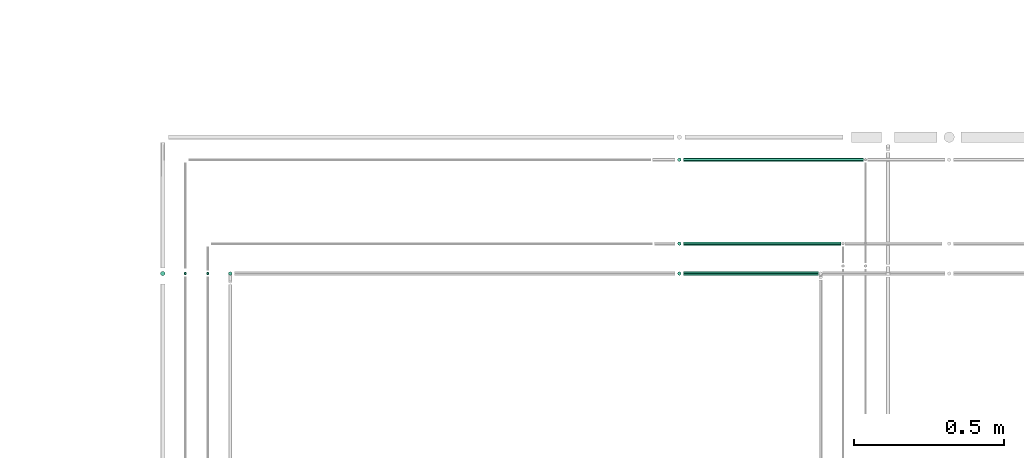
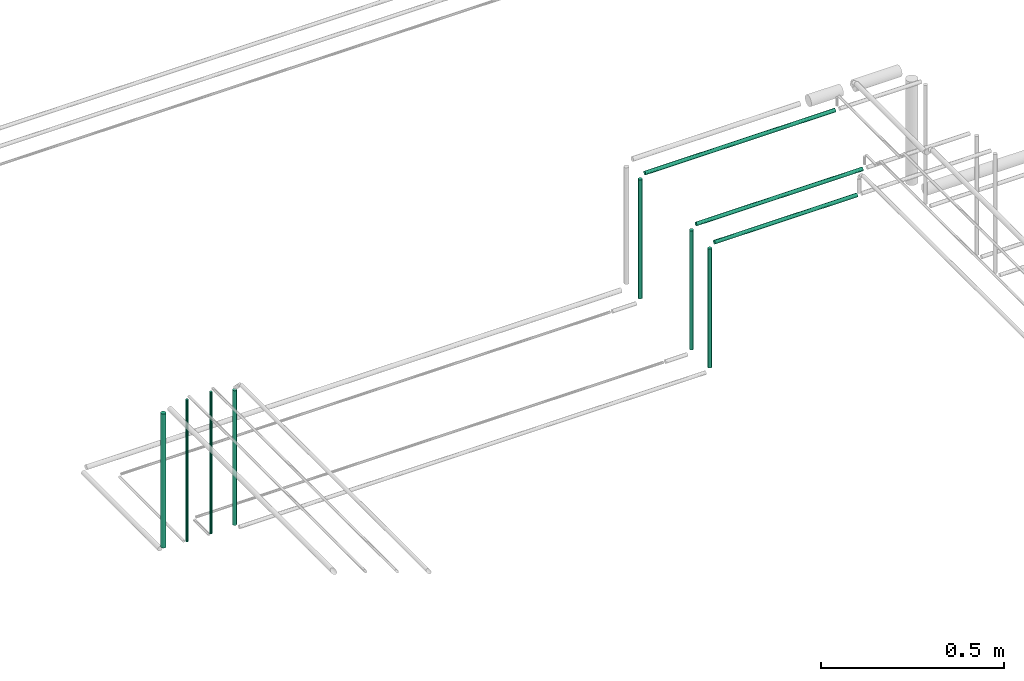
# One storey, part 162 of 331: 10 flow segments.
"""IFC2X3 building model written with IfcOpenShell, lengths in millimetres."""

from ifc_helpers import new_model, entity, si_unit, converted_unit, derived_unit, direction, frame, frame_2d, origin, origin_2d_with_axis, place, context, subcontext, project, spatial, circle, extrude, type_object, element, save


model = new_model("IFC2X3")

# Units and contexts
model_context = context("Model", 3, precision=0.01, world=origin(), true_north=direction((6.12303176911189e-17, 1.0)))
body_context = subcontext(model_context, "Body", "Model", "MODEL_VIEW")
ifc_project = project(units=[si_unit("LENGTHUNIT", "METRE", prefix="MILLI"), si_unit("AREAUNIT", "SQUARE_METRE"), si_unit("VOLUMEUNIT", "CUBIC_METRE"), converted_unit("PLANEANGLEUNIT", "DEGREE", entity("IfcRatioMeasure", 0.0174532925199433), si_unit("PLANEANGLEUNIT", "RADIAN"), dimensions=[0, 0, 0, 0, 0, 0, 0]), si_unit("MASSUNIT", "GRAM", prefix="KILO"), derived_unit("MASSDENSITYUNIT", [(si_unit("MASSUNIT", "GRAM", prefix="KILO"), 1), (si_unit("LENGTHUNIT", "METRE"), -3)]), derived_unit("MOMENTOFINERTIAUNIT", [(si_unit("LENGTHUNIT", "METRE"), 4)]), si_unit("TIMEUNIT", "SECOND"), si_unit("FREQUENCYUNIT", "HERTZ"), si_unit("THERMODYNAMICTEMPERATUREUNIT", "DEGREE_CELSIUS"), derived_unit("THERMALTRANSMITTANCEUNIT", [(si_unit("MASSUNIT", "GRAM", prefix="KILO"), 1), (si_unit("THERMODYNAMICTEMPERATUREUNIT", "KELVIN"), -1), (si_unit("TIMEUNIT", "SECOND"), -3)]), derived_unit("VOLUMETRICFLOWRATEUNIT", [(si_unit("LENGTHUNIT", "METRE"), 3), (si_unit("TIMEUNIT", "SECOND"), -1)]), derived_unit("MASSFLOWRATEUNIT", [(si_unit("MASSUNIT", "GRAM", prefix="KILO"), 1), (si_unit("TIMEUNIT", "SECOND"), -1)]), derived_unit("ROTATIONALFREQUENCYUNIT", [(si_unit("TIMEUNIT", "SECOND"), -1)]), si_unit("ELECTRICCURRENTUNIT", "AMPERE"), si_unit("ELECTRICVOLTAGEUNIT", "VOLT"), si_unit("POWERUNIT", "WATT"), si_unit("FORCEUNIT", "NEWTON", prefix="KILO"), si_unit("ILLUMINANCEUNIT", "LUX"), si_unit("LUMINOUSFLUXUNIT", "LUMEN"), si_unit("LUMINOUSINTENSITYUNIT", "CANDELA"), derived_unit("USERDEFINED", [(si_unit("MASSUNIT", "GRAM", prefix="KILO"), -1), (si_unit("LENGTHUNIT", "METRE"), -2), (si_unit("TIMEUNIT", "SECOND"), 3), (si_unit("LUMINOUSFLUXUNIT", "LUMEN"), 1)]), derived_unit("LINEARVELOCITYUNIT", [(si_unit("LENGTHUNIT", "METRE"), 1), (si_unit("TIMEUNIT", "SECOND"), -1)]), si_unit("PRESSUREUNIT", "PASCAL"), derived_unit("USERDEFINED", [(si_unit("LENGTHUNIT", "METRE"), -2), (si_unit("MASSUNIT", "GRAM", prefix="KILO"), 1), (si_unit("TIMEUNIT", "SECOND"), -2)]), derived_unit("LINEARFORCEUNIT", [(si_unit("MASSUNIT", "GRAM", prefix="KILO"), 1), (si_unit("LENGTHUNIT", "METRE"), 1), (si_unit("TIMEUNIT", "SECOND"), -2), (si_unit("LENGTHUNIT", "METRE"), -1)]), derived_unit("PLANARFORCEUNIT", [(si_unit("MASSUNIT", "GRAM", prefix="KILO"), 1), (si_unit("LENGTHUNIT", "METRE"), 1), (si_unit("TIMEUNIT", "SECOND"), -2), (si_unit("LENGTHUNIT", "METRE"), -2)])], contexts=[model_context])

# Site, building, storey
site_placement = place(None, frame((0.0, -0.00077364408347762, 0.0)))
site = spatial("IfcSite", under=ifc_project, at=site_placement, CompositionType="ELEMENT")
building_placement = place(site_placement, origin())
building = spatial("IfcBuilding", under=site, at=building_placement, CompositionType="ELEMENT")
storey_placement = place(building_placement, origin())
storey = spatial("IfcBuildingStorey", under=building, at=storey_placement, CompositionType="ELEMENT", Elevation=0.0)

# Flow segments
pipe_segment_type = type_object("IfcPipeSegmentType", PredefinedType="NOTDEFINED")
flow_segment_1_placement = place(storey_placement, frame((27663.5853972626, 13977.4043981742, 6764.0)))
element("IfcFlowSegment", 1, at=flow_segment_1_placement, inside=storey, type_object=pipe_segment_type, context=body_context, shape_type="SweptSolid", body=[
    extrude(circle(Radius=6.0, at=frame_2d((0.0, -2.16573425859679e-12), x_axis=(1.0, 0.0))), frame((7.59527223591454, 7.59527223591454, 0.0), z_axis=(0.0, 0.0, 1.0), x_axis=(-1.0, 0.0, 0.0)), (0.0, 0.0, 1.0), 449.112234222168),
])
flow_segment_2_placement = place(storey_placement, frame((29162.4047277641, 14357.4043981742, 6764.0)))
element("IfcFlowSegment", 2, at=flow_segment_2_placement, inside=storey, type_object=pipe_segment_type, context=body_context, shape_type="SweptSolid", body=[
    extrude(circle(Radius=6.0, at=origin_2d_with_axis()), frame((7.59527223591454, 7.5952722359167, 0.0), z_axis=(0.0, 0.0, 1.0), x_axis=(-1.0, 0.0, 0.0)), (0.0, 0.0, 1.0), 396.999999999996),
])
flow_segment_3_placement = place(building_placement, frame((29184.0, 14077.4043981742, 7167.40472776407)))
element("IfcFlowSegment", 3, at=flow_segment_3_placement, inside=storey, type_object=pipe_segment_type, context=body_context, shape_type="SweptSolid", body=[
    extrude(circle(Radius=6.0, at=frame_2d((1.29944055515807e-11, 0.0), x_axis=(1.0, 0.0))), frame((0.0, 7.59527223593403, 7.59527223591562), z_axis=(1.0, 0.0, 0.0), x_axis=(0.0, 1.0, 0.0)), (0.0, 0.0, 1.0), 525.036400398377),
])
flow_segment_4_placement = place(storey_placement, frame((29162.404727764, 14077.4043981742, 6764.0)))
element("IfcFlowSegment", 4, at=flow_segment_4_placement, inside=storey, type_object=pipe_segment_type, context=body_context, shape_type="SweptSolid", body=[
    extrude(circle(Radius=6.0, at=frame_2d((0.0, 2.16573425859679e-12), x_axis=(1.0, 0.0))), frame((7.59527223591454, 7.59527223591887, 0.0), z_axis=(0.0, 0.0, 1.0), x_axis=(-1.0, 0.0, 0.0)), (0.0, 0.0, 1.0), 396.999999999991),
])
flow_segment_5_placement = place(storey_placement, frame((29162.4047277641, 13977.4043981742, 6764.0)))
element("IfcFlowSegment", 5, at=flow_segment_5_placement, inside=storey, type_object=pipe_segment_type, context=body_context, shape_type="SweptSolid", body=[
    extrude(circle(Radius=6.0, at=frame_2d((0.0, -2.16573425859679e-12), x_axis=(1.0, 0.0))), frame((7.59527223591454, 7.59527223591454, 0.0), z_axis=(0.0, 0.0, 1.0), x_axis=(-1.0, 0.0, 0.0)), (0.0, 0.0, 1.0), 397.000000000004),
])
flow_segment_6_placement = place(building_placement, frame((29184.0, 13977.4043981742, 7167.40472776409)))
element("IfcFlowSegment", 6, at=flow_segment_6_placement, inside=storey, type_object=pipe_segment_type, context=body_context, shape_type="SweptSolid", body=[
    extrude(circle(Radius=6.0, at=frame_2d((-2.16573425859679e-12, 0.0), x_axis=(1.0, 0.0))), frame((0.0, 7.59527223591454, 7.59527223591562), z_axis=(1.0, 0.0, 0.0), x_axis=(0.0, -1.0, 0.0)), (0.0, 0.0, 1.0), 450.036400398295),
])
flow_segment_7_placement = place(building_placement, frame((27590.5853972626, 13979.4043981742, 6760.0)))
element("IfcFlowSegment", 7, at=flow_segment_7_placement, inside=storey, type_object=pipe_segment_type, context=body_context, shape_type="SweptSolid", body=[
    extrude(circle(Radius=4.0, at=origin_2d_with_axis()), frame((5.59527223591499, 5.59527223591499, 0.0)), (0.0, 0.0, 1.0), 472.999999999987),
])
flow_segment_8_placement = place(building_placement, frame((27437.0853972626, 13975.9043981742, 6768.0)))
element("IfcFlowSegment", 8, at=flow_segment_8_placement, inside=storey, type_object=pipe_segment_type, context=body_context, shape_type="SweptSolid", body=[
    extrude(circle(Radius=7.5, at=origin_2d_with_axis()), frame((9.09527223591419, 9.09527223591636, 0.0)), (0.0, 0.0, 1.0), 447.000000388623),
])
flow_segment_9_placement = place(storey_placement, frame((27515.5853972626, 13979.4043981742, 6760.0)))
element("IfcFlowSegment", 9, at=flow_segment_9_placement, inside=storey, type_object=pipe_segment_type, context=body_context, shape_type="SweptSolid", body=[
    extrude(circle(Radius=4.0, at=origin_2d_with_axis()), frame((5.59527223591499, 5.59527223591499, 0.0)), (0.0, 0.0, 1.0), 472.999999999987),
])
flow_segment_10_placement = place(building_placement, frame((29184.0, 14357.4043981742, 7167.40472776408)))
element("IfcFlowSegment", 10, at=flow_segment_10_placement, inside=storey, type_object=pipe_segment_type, context=body_context, shape_type="SweptSolid", body=[
    extrude(circle(Radius=6.0, at=origin_2d_with_axis()), frame((0.0, 7.5952722359167, 7.59527223591562), z_axis=(1.0, 0.0, 0.0), x_axis=(0.0, -1.0, 0.0)), (0.0, 0.0, 1.0), 600.036400398321),
])

save(model, "model.ifc")
